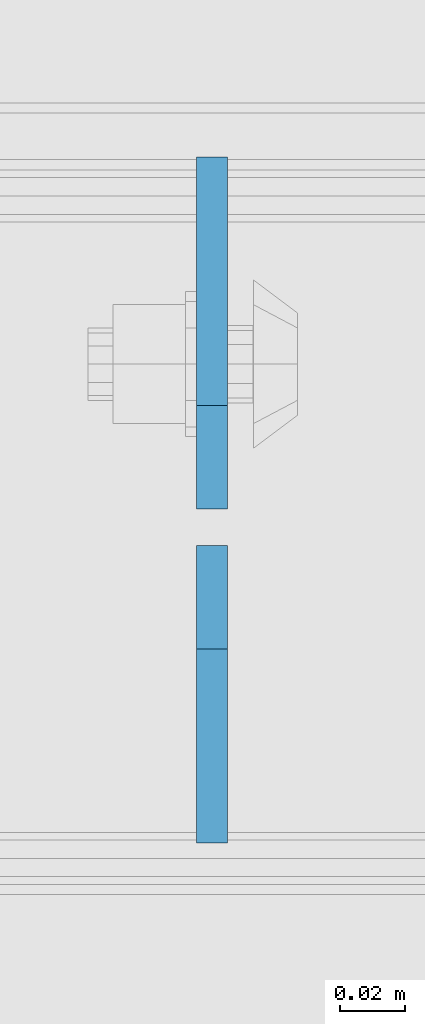
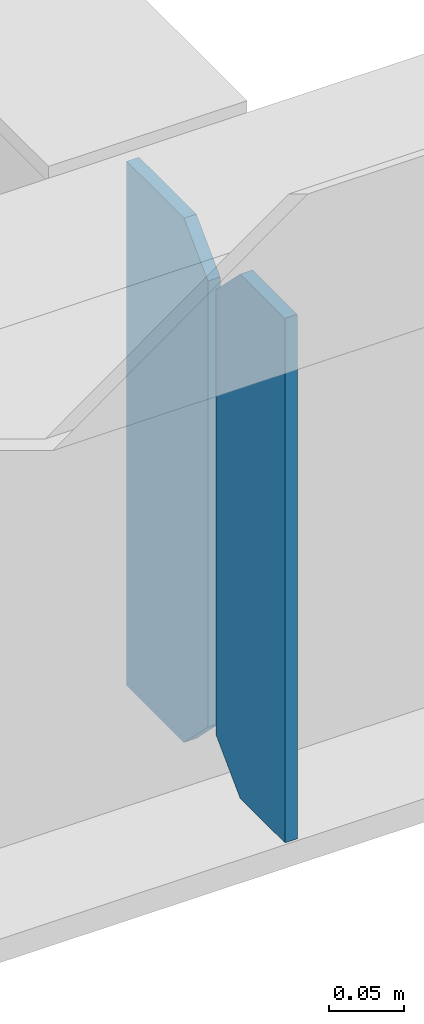
# One storey, part 3480 of 3843: 2 plates, 1 element without a shape of its own.
"""IFC2X3 building model written with IfcOpenShell, lengths in millimetres."""

from ifc_helpers import new_model, si_unit, frame, origin_with_axes, place, context, subcontext, project, spatial, faceted_brep, material, type_object, element, aggregate, save


model = new_model("IFC2X3")

# Units and contexts
model_context = context("Model", 3, precision=1e-05, world=origin_with_axes())
body_context = subcontext(model_context, "Body", "Model", "MODEL_VIEW")
ifc_project = project(units=[si_unit("LENGTHUNIT", "METRE", prefix="MILLI"), si_unit("AREAUNIT", "SQUARE_METRE"), si_unit("VOLUMEUNIT", "CUBIC_METRE"), si_unit("MASSUNIT", "GRAM", prefix="KILO"), si_unit("TIMEUNIT", "SECOND"), si_unit("PLANEANGLEUNIT", "RADIAN"), si_unit("SOLIDANGLEUNIT", "STERADIAN"), si_unit("THERMODYNAMICTEMPERATUREUNIT", "DEGREE_CELSIUS"), si_unit("LUMINOUSINTENSITYUNIT", "LUMEN")], contexts=[model_context])

# Site, building, storey
site_placement = place(None, origin_with_axes())
site = spatial("IfcSite", under=ifc_project, at=site_placement, CompositionType="ELEMENT")
building_placement = place(site_placement, origin_with_axes())
building = spatial("IfcBuilding", under=site, at=building_placement, Name="Undefined", CompositionType="ELEMENT")
storey_placement = place(building_placement, origin_with_axes())
storey = spatial("IfcBuildingStorey", under=building, at=storey_placement, Name="Undefined", CompositionType="ELEMENT", Elevation=0.0)

# Assembly, plates
assembly_placement = place(storey_placement, origin_with_axes())
assembly = element("IfcElementAssembly", 1, at=assembly_placement, inside=storey, Name="BEAM", AssemblyPlace="NOTDEFINED", PredefinedType="RIGID_FRAME")
ifc_material = material(Name="STEEL/A572-50")
plate_type_1 = type_object("IfcPlateType", PredefinedType="NOTDEFINED")
plate_1_placement = place(assembly_placement, frame((58157.2682500839, 92209.14375, 35990.2125), z_axis=(0.0, 0.0, 1.0), x_axis=(0.0, -1.0, 0.0)))
plate_1 = element("IfcPlate", 2, at=plate_1_placement, type_object=plate_type_1, material=ifc_material, Name="PLATE", context=body_context, shape_type="Brep", body=[
    faceted_brep([(0.0, -4.76249999999709, 31.75), (0.0, -4.76249999999709, 393.699999999997), (0.0, 4.76249999999709, 393.699999999997), (0.0, 4.76249999999709, 31.75), (31.75, -4.76249999999709, 425.449999999997), (31.75, 4.76249999999709, 425.449999999997), (91.28125, -4.76249999999709, 425.449999999997), (91.28125, 4.76249999999709, 425.449999999997), (91.28125, -4.76249999999709, 0.0), (91.28125, 4.76249999999709, 0.0), (31.75, -4.76249999999709, 0.0), (31.75, 4.76249999999709, 0.0)], [[[0, 1, 2, 3]], [[1, 4, 5, 2]], [[4, 6, 7, 5]], [[6, 8, 9, 7]], [[8, 10, 11, 9]], [[10, 0, 3, 11]], [[5, 7, 9, 11, 3, 2]], [[10, 8, 6, 4, 1, 0]]]),
])
plate_type_2 = type_object("IfcPlateType", PredefinedType="NOTDEFINED")
plate_2_placement = place(assembly_placement, frame((58157.2682500839, 92220.25625, 35990.2125), z_axis=(0.0, 0.0, 1.0), x_axis=(0.0, 1.0, 0.0)))
plate_2 = element("IfcPlate", 3, at=plate_2_placement, type_object=plate_type_2, material=ifc_material, Name="PLATE", context=body_context, shape_type="Brep", body=[
    faceted_brep([(0.0, -4.76249999999709, 31.75), (0.0, -4.76249999999709, 393.699999999997), (0.0, 4.76249999999709, 393.699999999997), (0.0, 4.76249999999709, 31.75), (31.75, -4.76249999999709, 425.449999999997), (31.75, 4.76249999999709, 425.449999999997), (107.950000000012, -4.76249999999709, 425.449999999997), (107.950000000012, 4.76249999999709, 425.449999999997), (107.950000000012, -4.76249999999709, 0.0), (107.950000000012, 4.76249999999709, 0.0), (31.75, -4.76249999999709, 0.0), (31.75, 4.76249999999709, 0.0)], [[[0, 1, 2, 3]], [[1, 4, 5, 2]], [[4, 6, 7, 5]], [[6, 8, 9, 7]], [[8, 10, 11, 9]], [[10, 0, 3, 11]], [[5, 7, 9, 11, 3, 2]], [[10, 8, 6, 4, 1, 0]]]),
])
aggregate(assembly, [plate_1, plate_2])

save(model, "model.ifc")
